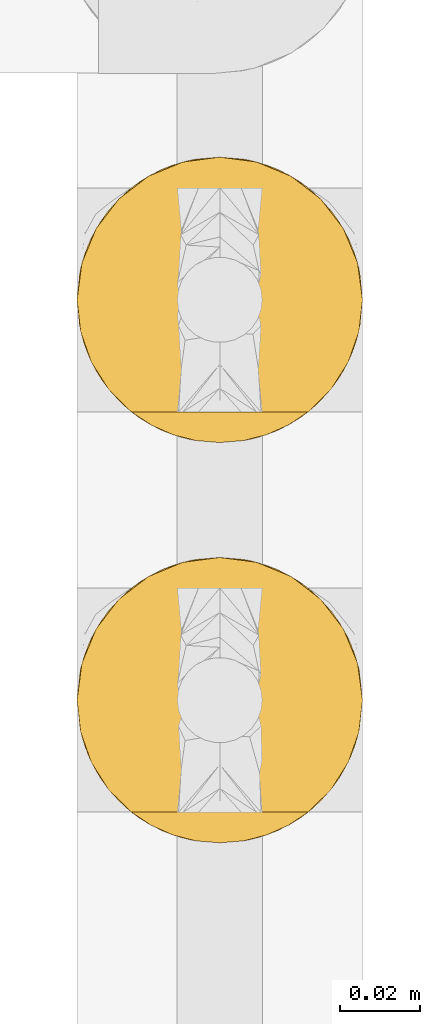
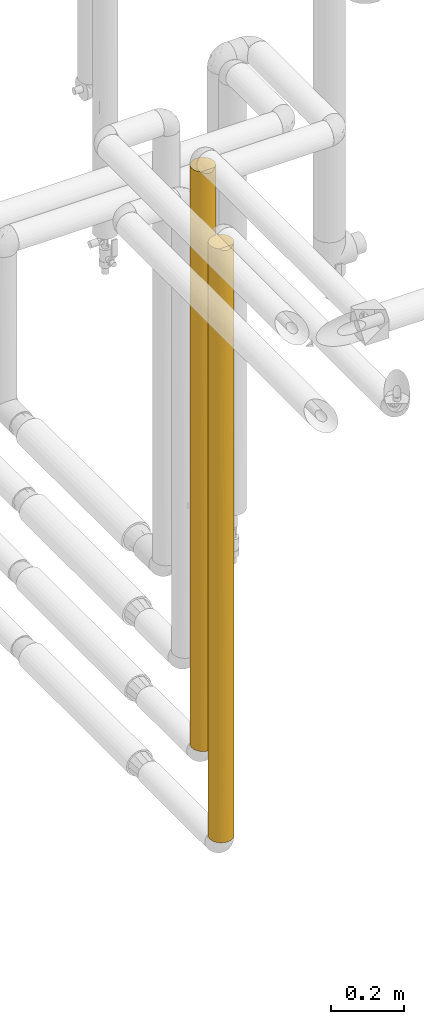
# One storey, part 28 of 827: 2 coverings.
"""IFC2X3 building model written with IfcOpenShell, lengths in millimetres."""

from ifc_helpers import new_model, entity, si_unit, converted_unit, derived_unit, direction, frame, origin, place, context, subcontext, project, spatial, faceted_brep, element, save


model = new_model("IFC2X3")

# Units and contexts
model_context = context("Model", 3, precision=0.01, world=origin(), true_north=direction((6.12303176911189e-17, 1.0)))
body_context = subcontext(model_context, "Body", "Model", "MODEL_VIEW")
ifc_project = project(units=[si_unit("LENGTHUNIT", "METRE", prefix="MILLI"), si_unit("AREAUNIT", "SQUARE_METRE"), si_unit("VOLUMEUNIT", "CUBIC_METRE"), converted_unit("PLANEANGLEUNIT", "DEGREE", entity("IfcRatioMeasure", 0.0174532925199433), si_unit("PLANEANGLEUNIT", "RADIAN"), dimensions=[0, 0, 0, 0, 0, 0, 0]), si_unit("MASSUNIT", "GRAM", prefix="KILO"), derived_unit("MASSDENSITYUNIT", [(si_unit("MASSUNIT", "GRAM", prefix="KILO"), 1), (si_unit("LENGTHUNIT", "METRE"), -3)]), derived_unit("MOMENTOFINERTIAUNIT", [(si_unit("LENGTHUNIT", "METRE"), 4)]), si_unit("TIMEUNIT", "SECOND"), si_unit("FREQUENCYUNIT", "HERTZ"), si_unit("THERMODYNAMICTEMPERATUREUNIT", "DEGREE_CELSIUS"), derived_unit("THERMALTRANSMITTANCEUNIT", [(si_unit("MASSUNIT", "GRAM", prefix="KILO"), 1), (si_unit("THERMODYNAMICTEMPERATUREUNIT", "KELVIN"), -1), (si_unit("TIMEUNIT", "SECOND"), -3)]), derived_unit("VOLUMETRICFLOWRATEUNIT", [(si_unit("LENGTHUNIT", "METRE"), 3), (si_unit("TIMEUNIT", "SECOND"), -1)]), derived_unit("MASSFLOWRATEUNIT", [(si_unit("MASSUNIT", "GRAM", prefix="KILO"), 1), (si_unit("TIMEUNIT", "SECOND"), -1)]), derived_unit("ROTATIONALFREQUENCYUNIT", [(si_unit("TIMEUNIT", "SECOND"), -1)]), si_unit("ELECTRICCURRENTUNIT", "AMPERE"), si_unit("ELECTRICVOLTAGEUNIT", "VOLT"), si_unit("POWERUNIT", "WATT"), si_unit("FORCEUNIT", "NEWTON", prefix="KILO"), si_unit("ILLUMINANCEUNIT", "LUX"), si_unit("LUMINOUSFLUXUNIT", "LUMEN"), si_unit("LUMINOUSINTENSITYUNIT", "CANDELA"), derived_unit("USERDEFINED", [(si_unit("MASSUNIT", "GRAM", prefix="KILO"), -1), (si_unit("LENGTHUNIT", "METRE"), -2), (si_unit("TIMEUNIT", "SECOND"), 3), (si_unit("LUMINOUSFLUXUNIT", "LUMEN"), 1)]), derived_unit("LINEARVELOCITYUNIT", [(si_unit("LENGTHUNIT", "METRE"), 1), (si_unit("TIMEUNIT", "SECOND"), -1)]), si_unit("PRESSUREUNIT", "PASCAL"), derived_unit("USERDEFINED", [(si_unit("LENGTHUNIT", "METRE"), -2), (si_unit("MASSUNIT", "GRAM", prefix="KILO"), 1), (si_unit("TIMEUNIT", "SECOND"), -2)]), derived_unit("LINEARFORCEUNIT", [(si_unit("MASSUNIT", "GRAM", prefix="KILO"), 1), (si_unit("LENGTHUNIT", "METRE"), 1), (si_unit("TIMEUNIT", "SECOND"), -2), (si_unit("LENGTHUNIT", "METRE"), -1)]), derived_unit("PLANARFORCEUNIT", [(si_unit("MASSUNIT", "GRAM", prefix="KILO"), 1), (si_unit("LENGTHUNIT", "METRE"), 1), (si_unit("TIMEUNIT", "SECOND"), -2), (si_unit("LENGTHUNIT", "METRE"), -2)])], contexts=[model_context])

# Site, building, storey
site_placement = place(None, origin())
site = spatial("IfcSite", under=ifc_project, at=site_placement, CompositionType="ELEMENT")
building_placement = place(site_placement, origin())
building = spatial("IfcBuilding", under=site, at=building_placement, CompositionType="ELEMENT")
storey_placement = place(building_placement, frame((0.0, 0.0, 28200.0)))
storey = spatial("IfcBuildingStorey", under=building, at=storey_placement, Name="08", CompositionType="ELEMENT", Elevation=28200.0)

# Coverings
covering_1_placement = place(storey_placement, frame((17891.28, 10623.96, 872.15)))
element("IfcCovering", 1, at=covering_1_placement, inside=storey, Name=":ADSK_", ObjectType=":ADSK_", PredefinedType="INSULATION", context=body_context, shape_type="Brep", body=[
    faceted_brep([(69.32, 21.68, 1949.98), (71.99, 29.26, 1949.98), (72.9, 37.25, 1949.98), (71.68, 46.47, 1949.98), (68.12, 55.07, 1949.98), (62.45, 62.45, 1949.98), (55.07, 68.12, 1949.98), (46.47, 71.68, 1949.98), (37.25, 72.9, 1949.98), (28.02, 71.68, 1949.98), (19.42, 68.12, 1949.98), (12.04, 62.45, 1949.98), (6.37, 55.07, 1949.98), (2.81, 46.47, 1949.98), (1.6, 37.25, 1949.98), (2.5, 29.26, 1949.98), (5.17, 21.68, 1949.98), (9.47, 14.9, 1949.98), (15.18, 9.25, 1949.98), (59.31, 9.25, 1949.98), (65.02, 14.9, 1949.98), (71.68, 28.02, 1.6), (68.12, 19.42, 1.6), (62.45, 12.04, 1.6), (55.07, 6.37, 1.6), (46.47, 2.81, 1.6), (37.25, 1.6, 1.6), (28.02, 2.81, 1.6), (19.42, 6.37, 1.6), (12.04, 12.04, 1.6), (6.37, 19.42, 1.6), (2.81, 28.02, 1.6), (1.6, 37.25, 1.6), (2.5, 45.24, 1.6), (5.17, 52.81, 1.6), (9.47, 59.6, 1.6), (15.18, 65.25, 1.6), (59.31, 65.25, 1.6), (65.02, 59.6, 1.6), (69.32, 52.81, 1.6), (71.99, 45.24, 1.6), (72.9, 37.25, 1.6), (15.54, 8.96, 169.87), (23.6, 4.31, 264.14), (15.54, 8.96, 385.28), (2.14, 31.06, 419.52), (1.6, 37.25, 558.82), (1.6, 37.25, 418.56), (1.6, 37.25, 280.21), (7.13, 18.17, 1501.69), (3.62, 25.39, 1680.83), (2.92, 27.61, 1354.44), (37.25, 1.6, 418.55), (30.64, 2.21, 314.32), (37.25, 1.6, 210.07), (4.31, 23.6, 385.28), (5.18, 21.66, 191.37), (8.96, 15.54, 264.14), (2.76, 28.21, 218.99), (3.41, 26.01, 1092.02), (7.56, 17.5, 1297.68), (31.32, 2.09, 1942.83), (25.57, 3.56, 1944.3), (30.19, 2.3, 1629.61), (1.6, 37.25, 1741.5), (1.6, 37.25, 1671.36), (1.6, 37.25, 1533.02), (7.13, 18.17, 1740.84), (22.55, 4.76, 550.12), (30.44, 2.25, 553.22), (7.7, 17.3, 886.74), (3.07, 27.1, 827.27), (5.33, 21.36, 731.28), (37.25, 1.6, 1733.85), (37.25, 1.6, 1942.33), (15.46, 9.03, 668.1), (12.09, 11.99, 1445.28), (12.17, 11.91, 1680.83), (22.65, 4.72, 1608.26), (27.28, 3.02, 1320.17), (10.41, 13.78, 477.16), (17.24, 7.74, 1309.75), (11.65, 12.43, 1215.38), (13.64, 10.53, 963.39), (16.62, 8.17, 1560.75), (17.49, 7.57, 1762.85), (30.5, 2.24, 1145.47), (37.25, 1.6, 1316.87), (20.14, 5.97, 1946.71), (3.33, 26.28, 599.34), (37.25, 1.6, 1525.36), (22.29, 4.88, 1101.99), (29.67, 2.41, 947.91), (1.6, 37.25, 1392.75), (1.6, 37.25, 1324.54), (1.6, 37.25, 1116.05), (37.25, 1.6, 1108.39), (8.96, 15.54, 690.18), (27.69, 2.9, 746.54), (21.54, 5.24, 836.2), (7.43, 17.7, 1092.5), (37.25, 1.6, 763.48), (1.6, 37.25, 210.07), (1.6, 37.25, 1114.14), (1.6, 37.25, 837.44), (1.6, 37.25, 835.52), (1.6, 37.25, 627.04), (58.95, 8.96, 169.87), (50.89, 4.31, 264.14), (43.85, 2.21, 314.32), (51.94, 4.76, 550.12), (44.05, 2.25, 553.22), (70.87, 25.39, 1680.83), (52.95, 5.24, 836.2), (59.03, 9.03, 668.1), (60.85, 10.53, 963.39), (65.53, 15.54, 264.14), (66.86, 17.4, 477.16), (58.95, 8.96, 385.28), (44.3, 2.3, 1629.61), (47.21, 3.02, 1320.17), (51.84, 4.72, 1608.26), (72.9, 37.25, 1741.5), (67.36, 18.17, 1501.69), (67.36, 18.17, 1740.84), (62.32, 11.91, 1680.83), (62.4, 11.99, 1445.28), (71.57, 27.61, 1354.44), (72.9, 37.25, 1533.02), (57.88, 8.17, 1560.75), (57.0, 7.57, 1762.85), (57.25, 7.74, 1309.75), (52.2, 4.88, 1101.99), (69.31, 21.66, 191.37), (71.73, 28.21, 218.99), (48.92, 3.56, 1944.3), (43.17, 2.09, 1942.83), (66.79, 17.3, 886.74), (71.73, 28.2, 1090.12), (67.06, 17.7, 1092.5), (69.16, 21.36, 731.28), (65.53, 15.54, 690.18), (72.9, 37.25, 210.08), (72.9, 37.25, 280.21), (72.35, 31.06, 419.52), (70.18, 23.6, 385.28), (71.17, 26.28, 599.34), (54.35, 5.97, 1946.71), (44.82, 2.41, 947.91), (44.06, 2.25, 751.2), (66.93, 17.5, 1297.68), (72.9, 37.25, 1324.54), (62.84, 12.43, 1215.38), (46.1, 2.71, 1133.6), (72.9, 37.25, 418.56), (72.9, 37.25, 558.83), (72.9, 37.25, 1671.37), (71.42, 27.1, 827.27), (72.9, 37.25, 837.44), (72.9, 37.25, 1114.14), (72.9, 37.25, 1116.06), (72.9, 37.25, 627.04), (72.9, 37.25, 835.52), (72.9, 37.25, 1392.75), (62.33, 62.58, 270.74), (67.36, 56.32, 449.89), (67.36, 56.32, 210.74), (52.95, 69.25, 1115.38), (59.03, 65.46, 1283.48), (60.85, 63.96, 988.18), (57.0, 66.92, 188.73), (51.84, 69.77, 343.32), (57.88, 66.32, 390.83), (69.16, 53.13, 1220.29), (66.79, 57.19, 1064.84), (65.53, 58.95, 1261.4), (70.87, 49.1, 270.75), (71.57, 46.88, 597.14), (71.73, 46.29, 861.46), (67.06, 56.79, 859.08), (43.85, 72.28, 1637.26), (50.89, 70.18, 1687.44), (71.73, 46.28, 1732.58), (65.53, 58.95, 1687.44), (44.3, 72.19, 321.97), (37.25, 72.9, 217.73), (37.25, 72.9, 426.21), (51.94, 69.73, 1401.46), (44.05, 72.24, 1398.36), (62.4, 62.5, 506.29), (69.31, 52.83, 1760.2), (47.21, 71.47, 631.41), (58.95, 65.53, 1781.71), (66.86, 57.09, 1474.42), (58.95, 65.53, 1566.3), (48.92, 70.93, 7.28), (43.17, 72.4, 8.75), (57.25, 66.75, 641.82), (52.2, 69.61, 849.59), (72.35, 43.43, 1532.06), (70.18, 50.89, 1566.3), (71.17, 48.22, 1352.23), (37.25, 72.9, 9.25), (54.35, 68.52, 4.87), (44.82, 72.08, 1003.67), (44.06, 72.24, 1200.37), (66.93, 56.99, 653.9), (62.84, 62.07, 736.2), (37.25, 72.9, 634.69), (46.1, 71.78, 817.98), (37.25, 72.9, 1741.5), (71.42, 47.39, 1124.31), (37.25, 72.9, 1533.02), (37.25, 72.9, 1188.09), (37.25, 72.9, 843.17), (12.17, 62.58, 270.74), (16.62, 66.32, 390.83), (17.49, 66.92, 188.73), (3.62, 49.1, 270.75), (7.13, 56.32, 210.74), (12.09, 62.5, 506.29), (7.13, 56.32, 449.89), (22.55, 69.73, 1401.46), (30.64, 72.28, 1637.26), (30.44, 72.24, 1398.36), (20.14, 68.52, 4.87), (25.57, 70.93, 7.28), (8.96, 58.95, 1687.44), (13.64, 63.96, 988.18), (17.24, 66.75, 641.82), (11.65, 62.07, 736.2), (15.54, 65.53, 1781.71), (23.6, 70.18, 1687.44), (15.54, 65.53, 1566.3), (2.14, 43.43, 1532.06), (7.56, 56.99, 653.9), (2.92, 46.88, 597.14), (3.41, 48.48, 859.55), (31.32, 72.4, 8.75), (7.7, 57.19, 1064.84), (3.07, 47.39, 1124.31), (5.33, 53.13, 1220.29), (4.31, 50.89, 1566.3), (2.76, 46.28, 1732.58), (5.18, 52.83, 1760.2), (30.19, 72.19, 321.97), (15.46, 65.46, 1283.48), (10.41, 60.71, 1474.42), (22.65, 69.77, 343.32), (27.28, 71.47, 631.41), (30.5, 72.25, 806.1), (3.33, 48.22, 1352.23), (22.29, 69.61, 849.59), (29.67, 72.08, 1003.67), (8.96, 58.95, 1261.4), (27.69, 71.59, 1205.04), (21.54, 69.25, 1115.38), (7.43, 56.79, 859.08)], [[[0, 1, 2, 3, 4, 5, 6, 7, 8, 9, 10, 11, 12, 13, 14, 15, 16, 17, 18, 19, 20]], [[21, 22, 23, 24, 25, 26, 27, 28, 29, 30, 31, 32, 33, 34, 35, 36, 37, 38, 39, 40, 41]], [[42, 29, 28]], [[43, 28, 27]], [[44, 42, 43]], [[45, 46, 47, 48]], [[49, 50, 51]], [[52, 53, 54]], [[55, 56, 57]], [[29, 57, 30]], [[55, 58, 56]], [[59, 60, 51]], [[61, 62, 63]], [[50, 64, 65, 66]], [[17, 16, 67]], [[68, 53, 69]], [[70, 71, 72]], [[73, 74, 61]], [[68, 75, 44]], [[76, 77, 49]], [[78, 79, 63]], [[55, 57, 80]], [[81, 82, 83]], [[67, 77, 17]], [[84, 85, 77]], [[17, 77, 18]], [[49, 67, 50]], [[84, 77, 76]], [[86, 87, 79]], [[81, 76, 82]], [[50, 16, 15]], [[88, 85, 62]], [[89, 72, 71]], [[58, 55, 45]], [[63, 62, 78]], [[90, 73, 63]], [[85, 88, 18]], [[50, 15, 64]], [[51, 50, 66]], [[68, 44, 43]], [[86, 91, 92]], [[51, 66, 93, 94, 95]], [[46, 45, 89]], [[87, 86, 96]], [[75, 83, 97]], [[61, 63, 73]], [[78, 81, 79]], [[91, 79, 81]], [[79, 90, 63]], [[27, 54, 53]], [[98, 68, 69]], [[42, 57, 29]], [[80, 57, 44]], [[15, 14, 64]], [[31, 58, 32]], [[50, 67, 16]], [[77, 67, 49]], [[71, 70, 59]], [[89, 71, 46]], [[68, 43, 53]], [[75, 68, 99]], [[83, 75, 99]], [[92, 96, 86]], [[75, 97, 80]], [[83, 99, 91]], [[83, 100, 70]], [[27, 26, 54]], [[53, 52, 69]], [[27, 53, 43]], [[52, 101, 69]], [[101, 92, 98]], [[83, 91, 81]], [[91, 99, 92]], [[98, 92, 99]], [[101, 96, 92]], [[58, 48, 102, 32]], [[89, 45, 55]], [[72, 55, 97]], [[71, 95, 103, 104, 105, 106, 46]], [[48, 58, 45]], [[56, 31, 30]], [[31, 56, 58]], [[57, 56, 30]], [[55, 72, 89]], [[70, 72, 97]], [[83, 70, 97]], [[70, 100, 59]], [[82, 60, 100]], [[84, 81, 78]], [[60, 76, 49]], [[83, 82, 100]], [[76, 60, 82]], [[51, 60, 49]], [[81, 84, 76]], [[78, 62, 85]], [[77, 85, 18]], [[78, 85, 84]], [[43, 42, 28]], [[57, 42, 44]], [[75, 80, 44]], [[87, 90, 79]], [[55, 80, 97]], [[60, 59, 100]], [[95, 59, 51]], [[95, 71, 59]], [[91, 86, 79]], [[68, 98, 99]], [[101, 98, 69]], [[107, 108, 24]], [[24, 108, 25]], [[109, 110, 111]], [[0, 112, 1]], [[113, 114, 115]], [[116, 117, 118]], [[110, 114, 113]], [[119, 120, 121]], [[112, 122, 1]], [[119, 73, 90]], [[123, 124, 125]], [[126, 123, 125]], [[116, 23, 22]], [[112, 127, 128]], [[121, 129, 130]], [[131, 132, 115]], [[133, 21, 134]], [[135, 136, 119]], [[120, 131, 121]], [[109, 25, 108]], [[137, 138, 139]], [[116, 118, 107]], [[0, 124, 112]], [[19, 125, 20]], [[20, 124, 0]], [[73, 119, 136]], [[24, 23, 107]], [[130, 135, 121]], [[140, 137, 141]], [[134, 41, 142, 143]], [[144, 134, 143]], [[145, 144, 146]], [[136, 74, 73]], [[130, 19, 147]], [[129, 131, 126]], [[127, 112, 123]], [[1, 122, 2]], [[120, 132, 131]], [[148, 149, 113]], [[127, 123, 150]], [[138, 151, 127]], [[126, 152, 150]], [[117, 146, 140]], [[90, 120, 119]], [[119, 121, 135]], [[120, 90, 87]], [[153, 132, 120]], [[133, 116, 22]], [[117, 116, 145]], [[110, 108, 118]], [[25, 54, 26]], [[125, 124, 20]], [[144, 143, 154, 155]], [[112, 128, 156, 122]], [[112, 124, 123]], [[157, 146, 155]], [[138, 158, 159, 160, 151]], [[118, 117, 114]], [[132, 148, 113]], [[118, 114, 110]], [[109, 111, 52]], [[141, 137, 115]], [[141, 115, 114]], [[115, 139, 152]], [[25, 109, 54]], [[52, 54, 109]], [[110, 109, 108]], [[149, 110, 113]], [[101, 52, 111]], [[153, 96, 148]], [[115, 132, 113]], [[96, 101, 148]], [[149, 148, 101]], [[157, 155, 161, 162, 158]], [[134, 144, 145]], [[155, 146, 144]], [[140, 146, 157]], [[133, 134, 145]], [[134, 21, 41]], [[116, 133, 145]], [[21, 133, 22]], [[157, 138, 137]], [[140, 141, 117]], [[157, 137, 140]], [[115, 137, 139]], [[129, 126, 125]], [[152, 126, 131]], [[115, 152, 131]], [[150, 152, 139]], [[150, 139, 138]], [[126, 150, 123]], [[125, 19, 130]], [[131, 129, 121]], [[130, 147, 135]], [[125, 130, 129]], [[116, 107, 23]], [[108, 107, 118]], [[117, 145, 146]], [[127, 151, 163, 128]], [[153, 87, 96]], [[117, 141, 114]], [[138, 127, 150]], [[158, 138, 157]], [[153, 120, 87]], [[148, 132, 153]], [[101, 111, 149]], [[149, 111, 110]], [[164, 165, 166]], [[167, 168, 169]], [[170, 171, 172]], [[173, 174, 175]], [[39, 176, 40]], [[39, 166, 176]], [[176, 142, 40]], [[176, 177, 154]], [[178, 179, 174]], [[166, 39, 38]], [[180, 7, 181]], [[182, 2, 122, 156]], [[4, 183, 5]], [[6, 181, 7]], [[184, 185, 186]], [[168, 167, 187]], [[187, 188, 180]], [[189, 165, 164]], [[3, 182, 190]], [[171, 184, 191]], [[6, 5, 192]], [[183, 193, 194]], [[195, 196, 184]], [[183, 4, 190]], [[192, 181, 6]], [[37, 164, 38]], [[191, 197, 171]], [[170, 195, 171]], [[197, 198, 169]], [[185, 184, 196]], [[199, 182, 156]], [[200, 199, 201]], [[196, 202, 185]], [[170, 37, 203]], [[172, 197, 189]], [[177, 176, 165]], [[40, 142, 41]], [[191, 198, 197]], [[204, 205, 167]], [[177, 165, 206]], [[178, 161, 177]], [[189, 207, 206]], [[193, 201, 173]], [[186, 191, 184]], [[184, 171, 195]], [[191, 186, 208]], [[209, 198, 191]], [[187, 181, 194]], [[7, 210, 8]], [[193, 183, 200]], [[192, 183, 194]], [[164, 166, 38]], [[199, 156, 128, 163]], [[176, 154, 143, 142]], [[176, 166, 165]], [[211, 201, 163]], [[178, 159, 158, 162, 161]], [[194, 193, 168]], [[198, 204, 167]], [[194, 168, 187]], [[180, 188, 212]], [[175, 174, 169]], [[175, 169, 168]], [[169, 179, 207]], [[7, 180, 210]], [[212, 210, 180]], [[187, 180, 181]], [[205, 187, 167]], [[213, 212, 188]], [[209, 214, 204]], [[169, 198, 167]], [[214, 213, 204]], [[205, 204, 213]], [[211, 163, 151, 160, 159]], [[182, 199, 200]], [[163, 201, 199]], [[173, 201, 211]], [[190, 182, 200]], [[182, 3, 2]], [[183, 190, 200]], [[3, 190, 4]], [[211, 178, 174]], [[173, 175, 193]], [[211, 174, 173]], [[169, 174, 179]], [[172, 189, 164]], [[207, 189, 197]], [[169, 207, 197]], [[206, 207, 179]], [[206, 179, 178]], [[189, 206, 165]], [[164, 37, 170]], [[197, 172, 171]], [[170, 203, 195]], [[164, 170, 172]], [[183, 192, 5]], [[181, 192, 194]], [[193, 200, 201]], [[177, 161, 155, 154]], [[209, 208, 214]], [[193, 175, 168]], [[178, 177, 206]], [[159, 178, 211]], [[209, 191, 208]], [[204, 198, 209]], [[213, 188, 205]], [[205, 188, 187]], [[215, 216, 217]], [[218, 102, 48, 47]], [[219, 215, 35]], [[216, 215, 220]], [[35, 215, 36]], [[35, 34, 219]], [[220, 215, 221]], [[222, 223, 224]], [[225, 217, 226]], [[11, 227, 12]], [[228, 229, 230]], [[231, 227, 11]], [[229, 220, 230]], [[232, 10, 9]], [[231, 232, 233]], [[234, 93, 66, 65]], [[235, 236, 237]], [[185, 202, 238]], [[218, 34, 33]], [[239, 240, 241]], [[242, 243, 244]], [[238, 226, 245]], [[222, 246, 233]], [[212, 223, 210]], [[231, 11, 10]], [[242, 227, 247]], [[248, 249, 245]], [[221, 219, 218]], [[221, 218, 236]], [[250, 208, 249]], [[251, 241, 240]], [[243, 242, 234]], [[245, 226, 248]], [[186, 185, 245]], [[217, 225, 36]], [[218, 33, 102]], [[236, 218, 47]], [[222, 233, 232]], [[250, 252, 253]], [[236, 47, 46, 106, 105]], [[93, 234, 251]], [[208, 250, 214]], [[246, 228, 254]], [[238, 245, 185]], [[248, 229, 249]], [[252, 249, 229]], [[249, 186, 245]], [[247, 227, 233]], [[244, 227, 242]], [[9, 210, 223]], [[255, 222, 224]], [[33, 32, 102]], [[13, 243, 14]], [[218, 219, 34]], [[215, 219, 221]], [[240, 239, 237]], [[251, 240, 93]], [[222, 232, 223]], [[246, 222, 256]], [[228, 246, 256]], [[253, 214, 250]], [[246, 254, 247]], [[228, 256, 252]], [[228, 257, 239]], [[9, 8, 210]], [[223, 212, 224]], [[9, 223, 232]], [[212, 213, 224]], [[213, 253, 255]], [[228, 252, 229]], [[252, 256, 253]], [[255, 253, 256]], [[213, 214, 253]], [[243, 65, 64, 14]], [[251, 234, 242]], [[241, 242, 254]], [[240, 105, 104, 103, 95, 94, 93]], [[65, 243, 234]], [[244, 13, 12]], [[13, 244, 243]], [[227, 244, 12]], [[242, 241, 251]], [[239, 241, 254]], [[228, 239, 254]], [[239, 257, 237]], [[230, 235, 257]], [[216, 229, 248]], [[235, 220, 221]], [[228, 230, 257]], [[220, 235, 230]], [[236, 235, 221]], [[229, 216, 220]], [[248, 226, 217]], [[215, 217, 36]], [[248, 217, 216]], [[232, 231, 10]], [[227, 231, 233]], [[246, 247, 233]], [[208, 186, 249]], [[242, 247, 254]], [[235, 237, 257]], [[105, 237, 236]], [[105, 240, 237]], [[252, 250, 249]], [[222, 255, 256]], [[213, 255, 224]], [[88, 62, 61, 74, 136, 135, 147, 19, 18]], [[225, 226, 238, 202, 196, 195, 203, 37, 36]]]),
])
covering_2_placement = place(storey_placement, frame((17891.28, 10523.96, 625.76)))
element("IfcCovering", 2, at=covering_2_placement, inside=storey, Name=":ADSK_", ObjectType=":ADSK_", PredefinedType="INSULATION", context=body_context, shape_type="Brep", body=[
    faceted_brep([(71.99, 29.26, 1997.97), (72.9, 37.25, 1997.97), (71.68, 46.47, 1997.97), (68.12, 55.07, 1997.97), (62.45, 62.45, 1997.97), (55.07, 68.12, 1997.97), (46.47, 71.68, 1997.97), (37.25, 72.9, 1997.97), (28.02, 71.68, 1997.97), (19.42, 68.12, 1997.97), (12.04, 62.45, 1997.97), (6.37, 55.07, 1997.97), (2.81, 46.47, 1997.97), (1.6, 37.25, 1997.97), (2.5, 29.26, 1997.97), (5.17, 21.68, 1997.97), (9.47, 14.89, 1997.97), (15.18, 9.25, 1997.97), (59.31, 9.25, 1997.97), (65.02, 14.89, 1997.97), (69.32, 21.68, 1997.97), (71.68, 28.02, 1.6), (68.12, 19.42, 1.6), (62.45, 12.04, 1.6), (55.07, 6.37, 1.6), (46.47, 2.81, 1.6), (37.25, 1.6, 1.6), (28.02, 2.81, 1.6), (19.42, 6.37, 1.6), (12.04, 12.04, 1.6), (6.37, 19.42, 1.6), (2.81, 28.02, 1.6), (1.6, 37.25, 1.6), (2.5, 45.24, 1.6), (5.17, 52.81, 1.6), (9.47, 59.6, 1.6), (15.18, 65.25, 1.6), (59.31, 65.25, 1.6), (65.02, 59.6, 1.6), (69.32, 52.81, 1.6), (71.99, 45.24, 1.6), (72.9, 37.25, 1.6), (67.36, 56.32, 210.74), (70.87, 49.1, 270.75), (65.53, 58.95, 1732.18), (71.57, 46.88, 597.14), (72.9, 37.25, 418.56), (72.9, 37.25, 210.08), (37.25, 72.9, 217.73), (44.3, 72.19, 321.97), (43.17, 72.4, 8.75), (67.36, 56.32, 449.89), (62.32, 62.58, 270.74), (72.11, 44.71, 1714.09), (72.9, 37.25, 1789.49), (72.9, 37.25, 1707.36), (48.92, 70.93, 7.28), (70.18, 50.89, 1824.02), (66.73, 57.29, 1509.4), (58.95, 65.53, 1604.16), (43.83, 72.28, 1685.25), (50.89, 70.18, 1732.18), (57.0, 66.92, 188.73), (51.84, 69.77, 343.32), (57.88, 66.32, 390.83), (58.95, 65.53, 1824.02), (37.25, 72.9, 426.21), (52.09, 69.66, 1135.58), (51.62, 69.87, 1434.15), (58.76, 65.67, 1296.18), (62.4, 62.5, 506.29), (71.68, 46.46, 867.48), (66.95, 56.96, 870.94), (68.69, 54.04, 1159.87), (47.21, 71.47, 631.41), (60.19, 64.53, 985.44), (43.94, 72.26, 1452.26), (69.94, 51.46, 1353.67), (65.53, 58.95, 1286.61), (64.92, 59.71, 1074.17), (57.25, 66.75, 641.82), (70.18, 50.89, 1604.16), (72.15, 44.51, 1490.68), (37.25, 72.9, 9.25), (54.35, 68.52, 4.87), (52.19, 69.61, 860.2), (44.71, 72.11, 995.2), (45.14, 72.01, 1224.53), (67.1, 56.74, 660.25), (72.9, 37.25, 627.04), (62.85, 62.05, 737.0), (37.25, 72.9, 1789.49), (37.25, 72.9, 634.69), (46.3, 71.73, 815.36), (72.9, 37.25, 292.21), (71.44, 47.33, 1136.87), (72.9, 37.25, 1416.75), (72.9, 37.25, 1372.53), (72.9, 37.25, 1164.04), (72.9, 37.25, 1126.13), (37.25, 72.9, 1581.01), (72.9, 37.25, 873.43), (72.9, 37.25, 835.52), (37.25, 72.9, 1396.55), (37.25, 72.9, 843.17), (37.25, 72.9, 1027.63), (37.25, 72.9, 1212.09), (72.9, 37.25, 1581.01), (72.9, 37.25, 582.82), (12.17, 62.58, 270.74), (16.62, 66.32, 390.83), (17.49, 66.92, 188.73), (3.62, 49.1, 270.75), (1.6, 37.25, 210.08), (1.6, 37.25, 292.21), (1.6, 37.25, 418.56), (7.13, 56.32, 210.74), (12.09, 62.5, 506.29), (7.13, 56.32, 449.89), (22.87, 69.87, 1434.15), (30.66, 72.28, 1685.25), (30.55, 72.26, 1452.26), (20.14, 68.52, 4.87), (25.57, 70.93, 7.28), (4.55, 51.46, 1353.67), (5.8, 54.04, 1159.87), (3.05, 47.33, 1136.87), (7.54, 56.96, 870.94), (9.57, 59.71, 1074.17), (15.54, 65.53, 1824.02), (8.96, 58.95, 1732.18), (17.24, 66.75, 641.82), (11.64, 62.05, 737.0), (23.6, 70.18, 1732.18), (7.39, 56.74, 660.25), (2.92, 46.88, 597.14), (3.41, 48.46, 865.99), (1.6, 37.25, 1707.36), (2.38, 44.71, 1714.09), (2.34, 44.51, 1490.68), (15.54, 65.53, 1604.16), (31.32, 72.4, 8.75), (4.31, 50.89, 1824.02), (15.73, 65.67, 1296.18), (30.19, 72.19, 321.97), (4.31, 50.89, 1604.16), (10.25, 60.53, 1509.4), (22.65, 69.77, 343.32), (27.28, 71.47, 631.41), (30.64, 72.28, 800.57), (22.3, 69.61, 860.2), (29.78, 72.11, 995.2), (1.6, 37.25, 582.82), (1.6, 37.25, 627.04), (1.6, 37.25, 835.52), (1.6, 37.25, 1416.75), (1.6, 37.25, 1581.01), (14.3, 64.53, 985.44), (29.35, 72.01, 1224.53), (22.4, 69.66, 1135.58), (1.6, 37.25, 1126.13), (8.96, 58.95, 1286.61), (1.6, 37.25, 1789.49), (1.6, 37.25, 873.43), (1.6, 37.25, 1164.04), (1.6, 37.25, 1372.53), (4.55, 23.03, 645.9), (5.8, 20.45, 839.69), (3.05, 27.16, 862.7), (23.6, 4.31, 267.38), (15.54, 8.96, 395.41), (15.54, 8.96, 175.54), (2.38, 29.78, 285.47), (2.34, 29.98, 508.89), (7.13, 18.17, 1549.68), (3.62, 25.39, 1728.82), (2.92, 27.61, 1402.42), (37.25, 1.6, 418.56), (30.66, 2.21, 314.32), (37.25, 1.6, 210.08), (4.31, 23.6, 395.41), (4.31, 23.6, 175.54), (8.96, 15.54, 267.38), (16.62, 8.17, 1608.74), (12.17, 11.91, 1728.82), (12.09, 11.99, 1493.27), (31.32, 2.09, 1990.81), (25.57, 3.56, 1992.29), (30.19, 2.3, 1677.6), (3.41, 26.03, 1133.57), (7.39, 17.75, 1339.32), (22.87, 4.62, 565.42), (30.55, 2.23, 547.31), (37.25, 1.6, 1781.84), (37.25, 1.6, 1990.32), (15.73, 8.82, 703.39), (22.65, 4.72, 1656.24), (27.28, 3.02, 1368.16), (10.25, 13.96, 490.17), (9.57, 14.78, 925.39), (7.54, 17.53, 1128.63), (7.13, 18.17, 1788.82), (17.49, 7.57, 1810.83), (30.64, 2.21, 1199.0), (37.25, 1.6, 1364.88), (17.24, 7.74, 1357.74), (11.64, 12.44, 1262.57), (20.14, 5.97, 1994.69), (37.25, 1.6, 1573.36), (22.3, 4.88, 1139.37), (29.78, 2.39, 1004.36), (37.25, 1.6, 603.02), (14.3, 9.96, 1014.13), (29.35, 2.48, 775.03), (22.4, 4.83, 863.99), (37.25, 1.6, 1156.39), (8.96, 15.54, 712.95), (37.25, 1.6, 787.48), (37.25, 1.6, 971.94), (58.95, 8.96, 175.54), (50.89, 4.31, 267.38), (43.83, 2.21, 314.32), (51.62, 4.62, 565.42), (43.94, 2.23, 547.31), (70.87, 25.39, 1728.82), (64.92, 14.78, 925.39), (58.76, 8.82, 703.39), (65.53, 15.54, 712.95), (52.09, 4.83, 863.99), (44.3, 2.3, 1677.6), (47.21, 3.02, 1368.16), (51.84, 4.72, 1656.24), (58.95, 8.96, 395.41), (65.53, 15.54, 267.38), (70.18, 23.6, 175.54), (62.4, 11.99, 1493.27), (67.36, 18.17, 1549.68), (62.32, 11.91, 1728.82), (57.88, 8.17, 1608.74), (57.0, 7.57, 1810.83), (60.19, 9.96, 1014.13), (66.73, 17.2, 490.17), (48.92, 3.56, 1992.29), (43.17, 2.09, 1990.81), (57.25, 7.74, 1357.74), (67.36, 18.17, 1788.82), (71.68, 28.03, 1132.09), (66.95, 17.53, 1128.63), (68.69, 20.45, 839.69), (71.57, 27.61, 1402.42), (69.94, 23.03, 645.9), (72.11, 29.78, 285.47), (70.18, 23.6, 395.41), (72.15, 29.98, 508.89), (54.35, 5.97, 1994.69), (52.19, 4.88, 1139.37), (44.71, 2.39, 1004.36), (45.14, 2.48, 775.03), (67.1, 17.75, 1339.32), (62.85, 12.44, 1262.57), (46.3, 2.77, 1184.21), (71.44, 27.16, 862.7)], [[[0, 1, 2, 3, 4, 5, 6, 7, 8, 9, 10, 11, 12, 13, 14, 15, 16, 17, 18, 19, 20]], [[21, 22, 23, 24, 25, 26, 27, 28, 29, 30, 31, 32, 33, 34, 35, 36, 37, 38, 39, 40, 41]], [[39, 42, 43]], [[44, 4, 3]], [[43, 45, 46]], [[43, 47, 40]], [[48, 49, 50]], [[51, 42, 52]], [[53, 1, 54, 55]], [[42, 39, 38]], [[56, 50, 49]], [[57, 3, 2]], [[44, 58, 59]], [[60, 6, 61]], [[62, 63, 64]], [[4, 65, 5]], [[49, 48, 66]], [[67, 68, 69]], [[65, 61, 5]], [[70, 51, 52]], [[71, 72, 73]], [[63, 49, 74]], [[69, 75, 67]], [[37, 52, 38]], [[39, 43, 40]], [[44, 3, 57]], [[68, 76, 60]], [[77, 73, 78]], [[79, 69, 78]], [[62, 56, 63]], [[5, 61, 6]], [[74, 80, 63]], [[53, 81, 57]], [[81, 53, 82]], [[50, 83, 48]], [[62, 37, 84]], [[64, 80, 70]], [[45, 43, 51]], [[52, 42, 38]], [[74, 85, 80]], [[67, 86, 87]], [[45, 51, 88]], [[71, 89, 45]], [[70, 90, 88]], [[82, 77, 81]], [[68, 61, 59]], [[6, 60, 91]], [[58, 44, 81]], [[65, 44, 59]], [[66, 74, 49]], [[55, 82, 53]], [[49, 63, 56]], [[74, 66, 92]], [[86, 85, 93]], [[43, 46, 94, 47]], [[47, 41, 40]], [[43, 42, 51]], [[59, 58, 69]], [[85, 86, 67]], [[95, 96, 97, 98, 99]], [[60, 76, 100]], [[71, 99, 101, 102, 89]], [[59, 69, 68]], [[78, 73, 79]], [[90, 75, 72]], [[85, 75, 80]], [[91, 60, 100]], [[91, 7, 6]], [[68, 60, 61]], [[87, 68, 67]], [[87, 103, 76]], [[93, 104, 86]], [[75, 85, 67]], [[87, 105, 106, 103]], [[105, 87, 86]], [[85, 74, 93]], [[68, 87, 76]], [[44, 65, 4]], [[61, 65, 59]], [[2, 1, 53]], [[44, 57, 81]], [[2, 53, 57]], [[82, 55, 107, 96]], [[96, 95, 82]], [[77, 82, 95]], [[73, 77, 95]], [[58, 77, 78]], [[71, 73, 95]], [[79, 72, 75]], [[72, 79, 73]], [[69, 79, 75]], [[64, 70, 52]], [[90, 70, 80]], [[75, 90, 80]], [[88, 90, 72]], [[88, 72, 71]], [[70, 88, 51]], [[52, 37, 62]], [[80, 64, 63]], [[62, 84, 56]], [[52, 62, 64]], [[77, 58, 81]], [[45, 89, 108, 46]], [[58, 78, 69]], [[71, 45, 88]], [[93, 92, 104]], [[99, 71, 95]], [[103, 100, 76]], [[93, 74, 92]], [[86, 104, 105]], [[109, 110, 111]], [[112, 113, 114, 115]], [[116, 109, 35]], [[110, 109, 117]], [[35, 109, 36]], [[112, 118, 116]], [[117, 109, 118]], [[119, 120, 121]], [[122, 111, 123]], [[124, 125, 126]], [[127, 125, 128]], [[129, 130, 10]], [[131, 117, 132]], [[133, 9, 8]], [[134, 135, 136]], [[137, 138, 139]], [[129, 133, 140]], [[48, 83, 141]], [[112, 34, 33]], [[10, 130, 11]], [[11, 142, 12]], [[100, 120, 91]], [[119, 143, 140]], [[141, 123, 144]], [[129, 10, 9]], [[145, 130, 146]], [[147, 148, 144]], [[35, 34, 116]], [[118, 112, 135]], [[149, 92, 148]], [[139, 124, 126]], [[142, 138, 12]], [[144, 123, 147]], [[66, 48, 144]], [[111, 122, 36]], [[112, 33, 113]], [[135, 112, 115]], [[119, 140, 133]], [[149, 150, 151]], [[135, 115, 152, 153, 154]], [[139, 155, 156, 137]], [[121, 100, 103]], [[157, 128, 143]], [[146, 130, 140]], [[142, 130, 145]], [[8, 91, 120]], [[158, 119, 121]], [[141, 144, 48]], [[12, 138, 13]], [[147, 131, 148]], [[150, 148, 131]], [[148, 66, 144]], [[33, 32, 113]], [[112, 116, 34]], [[109, 116, 118]], [[119, 133, 120]], [[143, 119, 159]], [[126, 125, 136]], [[151, 104, 149]], [[136, 160, 126]], [[143, 159, 157]], [[143, 161, 146]], [[150, 157, 159]], [[132, 157, 131]], [[8, 7, 91]], [[120, 100, 121]], [[8, 120, 133]], [[158, 103, 106, 105]], [[157, 150, 131]], [[150, 159, 151]], [[158, 151, 159]], [[158, 105, 151]], [[119, 158, 159]], [[158, 121, 103]], [[133, 129, 9]], [[130, 129, 140]], [[130, 142, 11]], [[138, 142, 145]], [[138, 145, 139]], [[138, 137, 162, 13]], [[124, 139, 145]], [[126, 155, 139]], [[146, 124, 145]], [[125, 124, 161]], [[128, 125, 161]], [[136, 125, 127]], [[143, 128, 161]], [[127, 128, 157]], [[132, 134, 127]], [[110, 131, 147]], [[134, 117, 118]], [[157, 132, 127]], [[117, 134, 132]], [[135, 134, 118]], [[131, 110, 117]], [[147, 123, 111]], [[109, 111, 36]], [[147, 111, 110]], [[143, 146, 140]], [[146, 161, 124]], [[134, 136, 127]], [[92, 66, 148]], [[154, 136, 135]], [[136, 154, 163, 160]], [[126, 160, 164, 165, 155]], [[92, 149, 104]], [[150, 149, 148]], [[105, 104, 151]], [[166, 167, 168]], [[169, 28, 27]], [[170, 171, 169]], [[114, 172, 173]], [[174, 175, 176]], [[177, 178, 179]], [[180, 181, 182]], [[29, 182, 30]], [[30, 181, 31]], [[183, 184, 185]], [[186, 187, 188]], [[175, 162, 137, 156]], [[189, 190, 176]], [[191, 178, 192]], [[29, 28, 171]], [[193, 194, 186]], [[191, 195, 170]], [[185, 184, 174]], [[196, 197, 188]], [[180, 182, 198]], [[167, 199, 200]], [[201, 184, 16]], [[183, 202, 184]], [[16, 184, 17]], [[174, 201, 175]], [[16, 15, 201]], [[203, 204, 197]], [[205, 185, 206]], [[175, 15, 14]], [[207, 202, 187]], [[173, 166, 168]], [[181, 172, 31]], [[188, 187, 196]], [[208, 193, 188]], [[202, 207, 17]], [[175, 14, 162]], [[176, 175, 156]], [[191, 170, 169]], [[203, 209, 210]], [[176, 156, 155, 165, 164]], [[173, 152, 115, 114]], [[192, 177, 211]], [[212, 199, 195]], [[27, 179, 178]], [[213, 191, 192]], [[171, 182, 29]], [[198, 182, 170]], [[186, 188, 193]], [[31, 172, 32]], [[196, 205, 197]], [[209, 197, 205]], [[197, 208, 188]], [[14, 13, 162]], [[175, 201, 15]], [[184, 201, 174]], [[191, 169, 178]], [[195, 191, 214]], [[168, 167, 189]], [[210, 215, 203]], [[189, 163, 168]], [[195, 214, 212]], [[195, 216, 198]], [[209, 212, 214]], [[206, 212, 205]], [[27, 26, 179]], [[178, 177, 192]], [[27, 178, 169]], [[213, 211, 217, 218]], [[212, 209, 205]], [[209, 214, 210]], [[213, 210, 214]], [[213, 218, 210]], [[191, 213, 214]], [[213, 192, 211]], [[169, 171, 28]], [[182, 171, 170]], [[182, 181, 30]], [[172, 181, 180]], [[172, 180, 173]], [[172, 114, 113, 32]], [[166, 173, 180]], [[168, 152, 173]], [[198, 166, 180]], [[167, 166, 216]], [[199, 167, 216]], [[189, 167, 200]], [[195, 199, 216]], [[200, 199, 212]], [[206, 190, 200]], [[183, 205, 196]], [[190, 185, 174]], [[212, 206, 200]], [[185, 190, 206]], [[176, 190, 174]], [[205, 183, 185]], [[196, 187, 202]], [[184, 202, 17]], [[196, 202, 183]], [[195, 198, 170]], [[198, 216, 166]], [[190, 189, 200]], [[204, 208, 197]], [[164, 189, 176]], [[189, 164, 160, 163]], [[168, 163, 154, 153, 152]], [[204, 203, 215]], [[209, 203, 197]], [[218, 215, 210]], [[219, 220, 24]], [[24, 220, 25]], [[221, 222, 223]], [[20, 224, 0]], [[225, 226, 227]], [[226, 228, 222]], [[221, 25, 220]], [[229, 230, 231]], [[232, 219, 233]], [[229, 193, 208]], [[234, 22, 21]], [[235, 236, 237]], [[233, 23, 22]], [[224, 54, 0]], [[231, 238, 239]], [[226, 240, 228]], [[233, 241, 232]], [[242, 243, 229]], [[230, 244, 231]], [[19, 245, 20]], [[246, 247, 248]], [[224, 249, 107]], [[24, 23, 219]], [[245, 237, 236]], [[20, 245, 224]], [[193, 229, 243]], [[18, 237, 19]], [[239, 242, 231]], [[250, 248, 227]], [[251, 41, 47, 94]], [[251, 252, 234]], [[252, 251, 253]], [[243, 194, 193]], [[239, 18, 254]], [[238, 244, 235]], [[249, 224, 236]], [[0, 54, 1]], [[230, 255, 244]], [[228, 256, 257]], [[249, 236, 258]], [[246, 97, 249]], [[235, 259, 258]], [[253, 250, 252]], [[234, 233, 22]], [[241, 233, 252]], [[222, 220, 232]], [[25, 179, 26]], [[208, 230, 229]], [[94, 253, 251]], [[229, 231, 242]], [[230, 208, 204]], [[256, 255, 260]], [[237, 245, 19]], [[224, 107, 55, 54]], [[224, 245, 236]], [[232, 241, 226]], [[255, 256, 228]], [[261, 108, 89, 102, 101]], [[221, 223, 177]], [[246, 101, 99, 98, 97]], [[232, 226, 222]], [[227, 248, 225]], [[259, 240, 247]], [[255, 240, 244]], [[25, 221, 179]], [[177, 179, 221]], [[222, 221, 220]], [[257, 222, 228]], [[257, 211, 223]], [[260, 215, 256]], [[240, 255, 228]], [[257, 218, 217, 211]], [[218, 257, 256]], [[255, 230, 260]], [[222, 257, 223]], [[233, 219, 23]], [[220, 219, 232]], [[21, 41, 251]], [[233, 234, 252]], [[21, 251, 234]], [[253, 94, 46, 108]], [[108, 261, 253]], [[250, 253, 261]], [[248, 250, 261]], [[241, 250, 227]], [[246, 248, 261]], [[225, 247, 240]], [[247, 225, 248]], [[226, 225, 240]], [[238, 235, 237]], [[259, 235, 244]], [[240, 259, 244]], [[258, 259, 247]], [[258, 247, 246]], [[235, 258, 236]], [[237, 18, 239]], [[244, 238, 231]], [[239, 254, 242]], [[237, 239, 238]], [[250, 241, 252]], [[249, 97, 96, 107]], [[241, 227, 226]], [[246, 249, 258]], [[260, 204, 215]], [[101, 246, 261]], [[211, 177, 223]], [[260, 230, 204]], [[256, 215, 218]], [[207, 187, 186, 194, 243, 242, 254, 18, 17]], [[122, 123, 141, 83, 50, 56, 84, 37, 36]]]),
])

save(model, "model.ifc")
